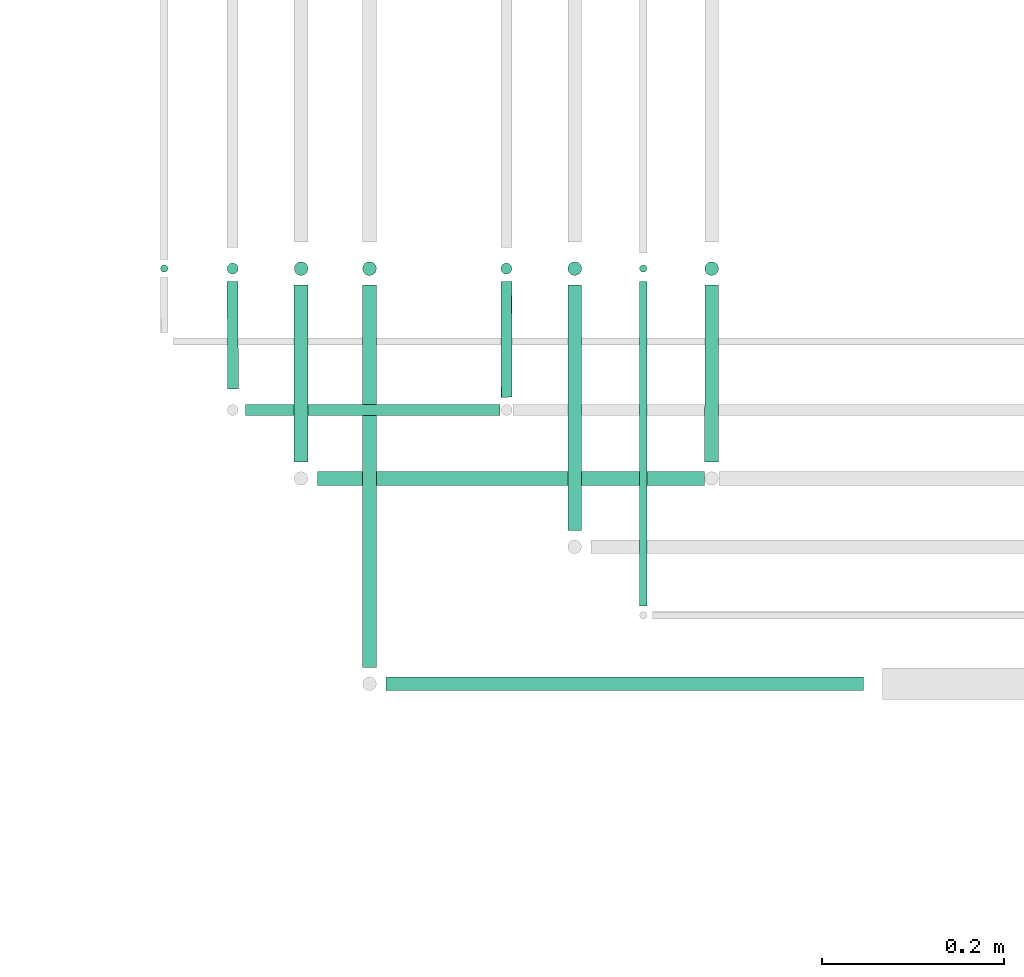
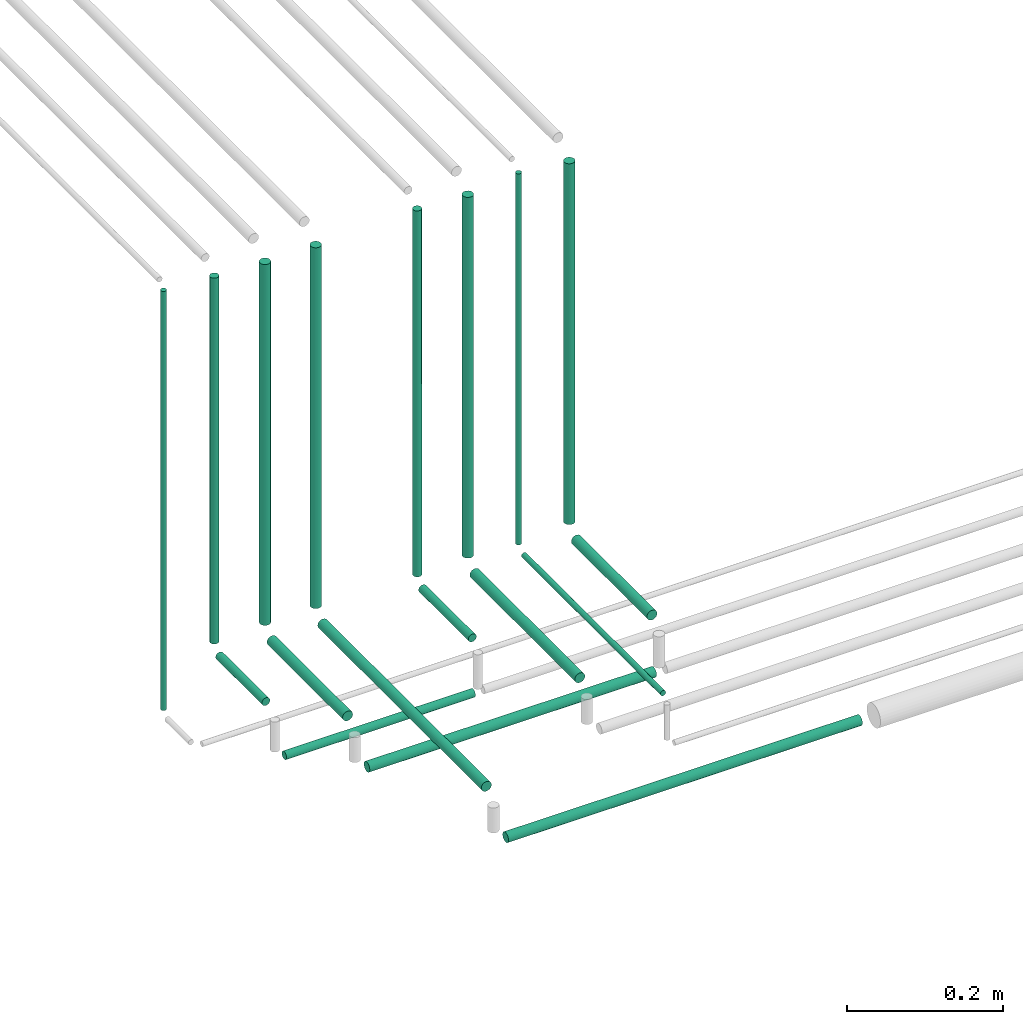
# One storey, part 31 of 65: 18 flow segments.
"""IFC2X3 building model written with IfcOpenShell, lengths in millimetres."""

from ifc_helpers import new_model, entity, si_unit, converted_unit, derived_unit, direction, frame, frame_2d, origin, origin_2d_with_axis, place, context, subcontext, project, spatial, circle, extrude, type_object, element, save


model = new_model("IFC2X3")

# Units and contexts
model_context = context("Model", 3, precision=0.01, world=origin(), true_north=direction((6.12303176911189e-17, 1.0)))
body_context = subcontext(model_context, "Body", "Model", "MODEL_VIEW")
ifc_project = project(units=[si_unit("LENGTHUNIT", "METRE", prefix="MILLI"), si_unit("AREAUNIT", "SQUARE_METRE"), si_unit("VOLUMEUNIT", "CUBIC_METRE"), converted_unit("PLANEANGLEUNIT", "DEGREE", entity("IfcRatioMeasure", 0.0174532925199433), si_unit("PLANEANGLEUNIT", "RADIAN"), dimensions=[0, 0, 0, 0, 0, 0, 0]), si_unit("MASSUNIT", "GRAM", prefix="KILO"), derived_unit("MASSDENSITYUNIT", [(si_unit("MASSUNIT", "GRAM", prefix="KILO"), 1), (si_unit("LENGTHUNIT", "METRE"), -3)]), derived_unit("MOMENTOFINERTIAUNIT", [(si_unit("LENGTHUNIT", "METRE"), 4)]), si_unit("TIMEUNIT", "SECOND"), si_unit("FREQUENCYUNIT", "HERTZ"), si_unit("THERMODYNAMICTEMPERATUREUNIT", "DEGREE_CELSIUS"), derived_unit("THERMALTRANSMITTANCEUNIT", [(si_unit("MASSUNIT", "GRAM", prefix="KILO"), 1), (si_unit("THERMODYNAMICTEMPERATUREUNIT", "KELVIN"), -1), (si_unit("TIMEUNIT", "SECOND"), -3)]), derived_unit("VOLUMETRICFLOWRATEUNIT", [(si_unit("LENGTHUNIT", "METRE"), 3), (si_unit("TIMEUNIT", "SECOND"), -1)]), derived_unit("MASSFLOWRATEUNIT", [(si_unit("MASSUNIT", "GRAM", prefix="KILO"), 1), (si_unit("TIMEUNIT", "SECOND"), -1)]), derived_unit("ROTATIONALFREQUENCYUNIT", [(si_unit("TIMEUNIT", "SECOND"), -1)]), si_unit("ELECTRICCURRENTUNIT", "AMPERE"), si_unit("ELECTRICVOLTAGEUNIT", "VOLT"), si_unit("POWERUNIT", "WATT"), si_unit("FORCEUNIT", "NEWTON", prefix="KILO"), si_unit("ILLUMINANCEUNIT", "LUX"), si_unit("LUMINOUSFLUXUNIT", "LUMEN"), si_unit("LUMINOUSINTENSITYUNIT", "CANDELA"), derived_unit("USERDEFINED", [(si_unit("MASSUNIT", "GRAM", prefix="KILO"), -1), (si_unit("LENGTHUNIT", "METRE"), -2), (si_unit("TIMEUNIT", "SECOND"), 3), (si_unit("LUMINOUSFLUXUNIT", "LUMEN"), 1)]), derived_unit("LINEARVELOCITYUNIT", [(si_unit("LENGTHUNIT", "METRE"), 1), (si_unit("TIMEUNIT", "SECOND"), -1)]), si_unit("PRESSUREUNIT", "PASCAL"), derived_unit("USERDEFINED", [(si_unit("LENGTHUNIT", "METRE"), -2), (si_unit("MASSUNIT", "GRAM", prefix="KILO"), 1), (si_unit("TIMEUNIT", "SECOND"), -2)]), derived_unit("LINEARFORCEUNIT", [(si_unit("MASSUNIT", "GRAM", prefix="KILO"), 1), (si_unit("LENGTHUNIT", "METRE"), 1), (si_unit("TIMEUNIT", "SECOND"), -2), (si_unit("LENGTHUNIT", "METRE"), -1)]), derived_unit("PLANARFORCEUNIT", [(si_unit("MASSUNIT", "GRAM", prefix="KILO"), 1), (si_unit("LENGTHUNIT", "METRE"), 1), (si_unit("TIMEUNIT", "SECOND"), -2), (si_unit("LENGTHUNIT", "METRE"), -2)])], contexts=[model_context])

# Site, building, storey
site_placement = place(None, frame((0.0, -0.00077364408347762, 0.0)))
site = spatial("IfcSite", under=ifc_project, at=site_placement, CompositionType="ELEMENT")
building_placement = place(site_placement, origin())
building = spatial("IfcBuilding", under=site, at=building_placement, CompositionType="ELEMENT")
storey_placement = place(building_placement, frame((0.0, 0.0, 19800.0)))
storey = spatial("IfcBuildingStorey", under=building, at=storey_placement, CompositionType="ELEMENT", Elevation=19800.0)

# Flow segments
pipe_segment_type = type_object("IfcPipeSegmentType", PredefinedType="NOTDEFINED")
flow_segment_1_placement = place(storey_placement, frame((37449.8041526611, 7192.40472776405, 2467.40472776407)))
element("IfcFlowSegment", 1, at=flow_segment_1_placement, inside=storey, type_object=pipe_segment_type, context=body_context, shape_type="SweptSolid", body=[
    extrude(circle(Radius=6.0, at=frame_2d((-2.92374124910566e-11, 0.0), x_axis=(1.0, 0.0))), frame((0.0, 7.59527223594594, 7.59527223591454), z_axis=(1.0, 0.0, 0.0), x_axis=(0.0, 1.0, 0.0)), (0.0, 0.0, 1.0), 279.257560251528),
])
flow_segment_2_placement = place(storey_placement, frame((37528.6857346528, 7115.90472776404, 2465.90472776406)))
element("IfcFlowSegment", 2, at=flow_segment_2_placement, inside=storey, type_object=pipe_segment_type, context=body_context, shape_type="SweptSolid", body=[
    extrude(circle(Radius=7.5, at=frame_2d((-3.24860138789518e-11, 0.0), x_axis=(1.0, 0.0))), frame((0.0, 9.09527223594776, 9.09527223591419), z_axis=(1.0, 0.0, 0.0), x_axis=(0.0, 1.0, 0.0)), (0.0, 0.0, 1.0), 424.000972716052),
])
flow_segment_3_placement = place(storey_placement, frame((37603.8612434505, 6890.90472776408, 2465.90472776408)))
element("IfcFlowSegment", 3, at=flow_segment_3_placement, inside=storey, type_object=pipe_segment_type, context=body_context, shape_type="SweptSolid", body=[
    extrude(circle(Radius=7.5, at=frame_2d((1.08286712929839e-12, 0.0), x_axis=(1.0, 0.0))), frame((0.0, 9.09527223591744, 9.09527223591419), z_axis=(1.0, 0.0, 0.0), x_axis=(0.0, 1.0, 0.0)), (0.0, 0.0, 1.0), 523.28122274743),
])
flow_segment_4_placement = place(storey_placement, frame((37355.2088804252, 7349.4047277641, 2485.0)))
element("IfcFlowSegment", 4, at=flow_segment_4_placement, inside=storey, type_object=pipe_segment_type, context=body_context, shape_type="SweptSolid", body=[
    extrude(circle(Radius=4.0, at=origin_2d_with_axis()), frame((5.59527223591499, 5.59527223591607, 0.0), z_axis=(0.0, 0.0, 1.0), x_axis=(-1.0, 0.0, 0.0)), (0.0, 0.0, 1.0), 654.999999999981),
])
flow_segment_5_placement = place(storey_placement, frame((37428.2088804257, 7347.40472776409, 2563.9999254711)))
element("IfcFlowSegment", 5, at=flow_segment_5_placement, inside=storey, type_object=pipe_segment_type, context=body_context, shape_type="SweptSolid", body=[
    extrude(circle(Radius=6.0, at=frame_2d((5.38032601456588e-17, 9.55695823947059e-20), x_axis=(1.0, 0.0))), frame((7.60237732340993, 7.5952848565306, 7.45289019278062e-05), z_axis=(-1.24214824446003e-05, -2.20640140919228e-08, 1.0), x_axis=(-1.0, 0.0, -1.24214824446003e-05)), (0.0, 0.0, 1.0), 572.000000044145),
])
flow_segment_6_placement = place(storey_placement, frame((37428.2159949786, 7222.98934235126, 2542.40472776409)))
element("IfcFlowSegment", 6, at=flow_segment_6_placement, inside=storey, type_object=pipe_segment_type, context=body_context, shape_type="SweptSolid", body=[
    extrude(circle(Radius=6.0, at=origin_2d_with_axis()), frame((7.80486354928737, 0.0106576487671276, 7.59527223591454), z_axis=(-0.00177627479454755, 0.999998422422683, 0.0), x_axis=(-0.999998422422683, -0.00177627479454755, 0.0)), (0.0, 0.0, 1.0), 118.000198775034),
])
flow_segment_7_placement = place(storey_placement, frame((37501.7089301117, 7345.90472785234, 2567.99990683827)))
element("IfcFlowSegment", 7, at=flow_segment_7_placement, inside=storey, type_object=pipe_segment_type, context=body_context, shape_type="SweptSolid", body=[
    extrude(circle(Radius=7.5, at=origin_2d_with_axis()), frame((9.10227795143928, 9.09528468002075, 9.31611165810864e-05), z_axis=(-1.24214824479029e-05, -2.20640148706066e-08, 1.0), x_axis=(-1.0, 0.0, -1.24214824479029e-05)), (0.0, 0.0, 1.0), 564.00000004476),
])
flow_segment_8_placement = place(storey_placement, frame((37501.6011211214, 7142.99596146858, 2540.9047277641)))
element("IfcFlowSegment", 8, at=flow_segment_8_placement, inside=storey, type_object=pipe_segment_type, context=body_context, shape_type="SweptSolid", body=[
    extrude(circle(Radius=7.5, at=origin_2d_with_axis()), frame((9.09527115029658, 0.00403537630627113, 9.09527223591419), z_axis=(0.00053805017416417, 0.999999855250995, 0.0), x_axis=(0.999999855250995, -0.00053805017416417, 0.0)), (0.0, 0.0, 1.0), 194.000047321078),
])
flow_segment_9_placement = place(storey_placement, frame((37576.7089301117, 7345.90472785234, 2567.99990683827)))
element("IfcFlowSegment", 9, at=flow_segment_9_placement, inside=storey, type_object=pipe_segment_type, context=body_context, shape_type="SweptSolid", body=[
    extrude(circle(Radius=7.5, at=origin_2d_with_axis()), frame((9.10227795143928, 9.09528468002075, 9.31611165810864e-05), z_axis=(-1.24214824479029e-05, -2.20640148706066e-08, 1.0), x_axis=(-1.0, 0.0, -1.24214824479029e-05)), (0.0, 0.0, 1.0), 564.00000004476),
])
flow_segment_10_placement = place(storey_placement, frame((37576.716894245, 6917.9991346705, 2540.90472776409)))
element("IfcFlowSegment", 10, at=flow_segment_10_placement, inside=storey, type_object=pipe_segment_type, context=body_context, shape_type="SweptSolid", body=[
    extrude(circle(Radius=7.5, at=origin_2d_with_axis()), frame((9.09527218599835, 419.000878274018, 9.09527223591419), z_axis=(0.000115375266442072, -0.999999993344274, 0.0), x_axis=(0.999999993344274, 0.000115375266442072, 0.0)), (0.0, 0.0, 1.0), 419.000015854193),
])
flow_segment_11_placement = place(storey_placement, frame((37728.2088804257, 7347.40472776409, 2563.9999254711)))
element("IfcFlowSegment", 11, at=flow_segment_11_placement, inside=storey, type_object=pipe_segment_type, context=body_context, shape_type="SweptSolid", body=[
    extrude(circle(Radius=6.0, at=frame_2d((5.38032601456588e-17, 1.08286722486798e-12), x_axis=(1.0, 0.0))), frame((7.60237732340993, 7.59528485653276, 7.45289019278062e-05), z_axis=(-1.24214824446003e-05, -2.20640140919228e-08, 1.0), x_axis=(-1.0, 0.0, -1.24214824446003e-05)), (0.0, 0.0, 1.0), 572.000000044145),
])
flow_segment_12_placement = place(storey_placement, frame((37728.2159949787, 7213.98932026511, 2542.40472776409)))
element("IfcFlowSegment", 12, at=flow_segment_12_placement, inside=storey, type_object=pipe_segment_type, context=body_context, shape_type="SweptSolid", body=[
    extrude(circle(Radius=6.0, at=origin_2d_with_axis()), frame((7.82085008689194, 0.0106576487671276, 7.59527223591454), z_axis=(-0.00177627479456787, 0.999998422422683, 0.0), x_axis=(0.999998422422683, 0.00177627479456787, 0.0)), (0.0, 0.0, 1.0), 127.00023505943),
])
flow_segment_13_placement = place(storey_placement, frame((37801.7089301117, 7345.90472785234, 2567.99990683827)))
element("IfcFlowSegment", 13, at=flow_segment_13_placement, inside=storey, type_object=pipe_segment_type, context=body_context, shape_type="SweptSolid", body=[
    extrude(circle(Radius=7.5, at=origin_2d_with_axis()), frame((9.10227795143928, 9.09528468002183, 9.31611165810864e-05), z_axis=(-1.24214824479029e-05, -2.20640148706066e-08, 1.0), x_axis=(-1.0, 0.0, -1.24214824479029e-05)), (0.0, 0.0, 1.0), 564.00000004476),
])
flow_segment_14_placement = place(storey_placement, frame((37801.5607673528, 7067.99596201824, 2540.90472776411)))
element("IfcFlowSegment", 14, at=flow_segment_14_placement, inside=storey, type_object=pipe_segment_type, context=body_context, shape_type="SweptSolid", body=[
    extrude(circle(Radius=7.5, at=origin_2d_with_axis()), frame((9.09527115029658, 0.004035376307354, 9.09527223591419), z_axis=(0.000538050174169449, 0.999999855250995, 0.0), x_axis=(0.999999855250995, -0.000538050174169449, 0.0)), (0.0, 0.0, 1.0), 269.000057627596),
])
flow_segment_15_placement = place(storey_placement, frame((37880.2088307396, 7349.40472767583, 2559.99995031468)))
element("IfcFlowSegment", 15, at=flow_segment_15_placement, inside=storey, type_object=pipe_segment_type, context=body_context, shape_type="SweptSolid", body=[
    extrude(circle(Radius=4.0, at=frame_2d((5.38032601317474e-17, 9.55695791149041e-20), x_axis=(1.0, 0.0))), frame((5.602476695424, 5.59528503304273, 4.96859288432461e-05), z_axis=(-1.24214824413886e-05, -2.20640133347196e-08, 1.0), x_axis=(-1.0, 0.0, -1.24214824413886e-05)), (0.0, 0.0, 1.0), 580.000000043539),
])
flow_segment_16_placement = place(storey_placement, frame((37880.2159855132, 6985.0, 2544.40472776412)))
element("IfcFlowSegment", 16, at=flow_segment_16_placement, inside=storey, type_object=pipe_segment_type, context=body_context, shape_type="SweptSolid", body=[
    extrude(circle(Radius=4.0, at=origin_2d_with_axis()), frame((5.59527223591499, 0.0, 5.59527223591499), z_axis=(0.0, 1.0, 0.0), x_axis=(1.0, 0.0, 0.0)), (0.0, 0.0, 1.0), 356.000012620585),
])
flow_segment_17_placement = place(storey_placement, frame((37951.7089301117, 7345.90472785234, 2567.99990683827)))
element("IfcFlowSegment", 17, at=flow_segment_17_placement, inside=storey, type_object=pipe_segment_type, context=body_context, shape_type="SweptSolid", body=[
    extrude(circle(Radius=7.5, at=origin_2d_with_axis()), frame((9.10227795143928, 9.09528468002183, 9.31611165810864e-05), z_axis=(-1.24214824479029e-05, -2.20640148706066e-08, 1.0), x_axis=(-1.0, 0.0, -1.24214824479029e-05)), (0.0, 0.0, 1.0), 564.00000004476),
])
flow_segment_18_placement = place(storey_placement, frame((37951.601121142, 7142.99592441319, 2540.9047277641)))
element("IfcFlowSegment", 18, at=flow_segment_18_placement, inside=storey, type_object=pipe_segment_type, context=body_context, shape_type="SweptSolid", body=[
    extrude(circle(Radius=7.5, at=origin_2d_with_axis()), frame((9.095271129969, 0.00407298128754405, 9.09527223591419), z_axis=(0.000543064171714496, 0.999999852540642, 0.0), x_axis=(0.999999852540642, -0.000543064171714496, 0.0)), (0.0, 0.0, 1.0), 194.000046747646),
])

save(model, "model.ifc")
